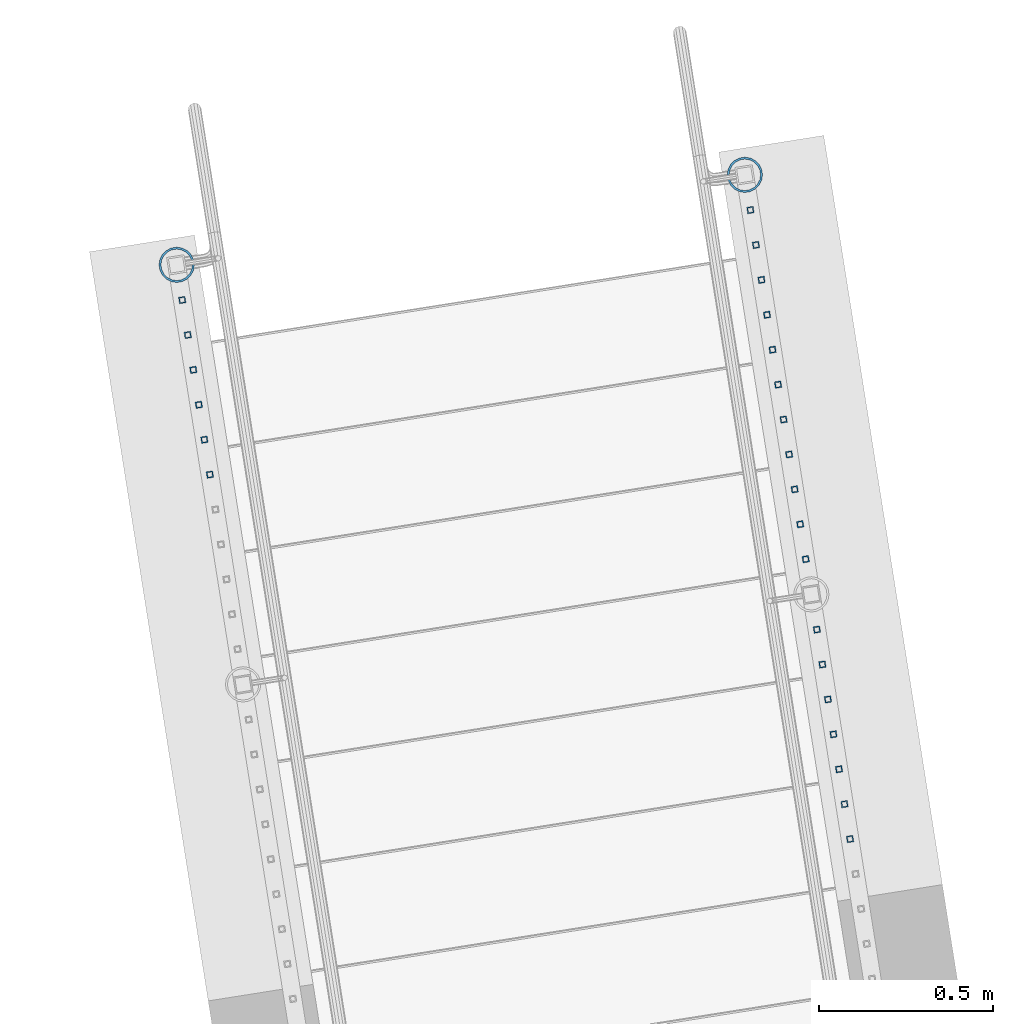
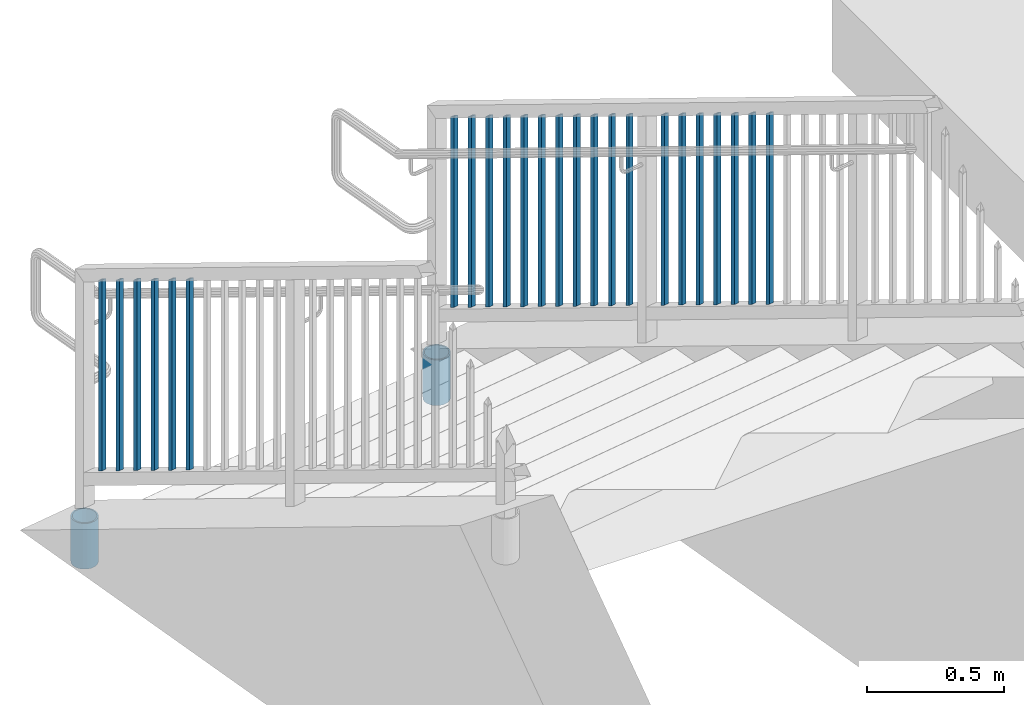
# One storey, part 229 of 975: 26 columns.
"""IFC2X3 building model written with IfcOpenShell, lengths in millimetres."""

from ifc_helpers import new_model, si_unit, frame, origin_with_axes, place, context, subcontext, project, spatial, faceted_brep, material, type_object, element, save


model = new_model("IFC2X3")

# Units and contexts
model_context = context("Model", 3, precision=1e-05, world=origin_with_axes())
body_context = subcontext(model_context, "Body", "Model", "MODEL_VIEW")
ifc_project = project(units=[si_unit("LENGTHUNIT", "METRE", prefix="MILLI"), si_unit("AREAUNIT", "SQUARE_METRE"), si_unit("VOLUMEUNIT", "CUBIC_METRE"), si_unit("MASSUNIT", "GRAM", prefix="KILO"), si_unit("TIMEUNIT", "SECOND"), si_unit("PLANEANGLEUNIT", "RADIAN"), si_unit("SOLIDANGLEUNIT", "STERADIAN"), si_unit("THERMODYNAMICTEMPERATUREUNIT", "DEGREE_CELSIUS"), si_unit("LUMINOUSINTENSITYUNIT", "LUMEN")], contexts=[model_context])

# Site, building, storey
site_placement = place(None, origin_with_axes())
site = spatial("IfcSite", under=ifc_project, at=site_placement, CompositionType="ELEMENT")
building_placement = place(site_placement, origin_with_axes())
building = spatial("IfcBuilding", under=site, at=building_placement, Name="Undefined", CompositionType="ELEMENT")
storey_placement = place(building_placement, origin_with_axes())
storey = spatial("IfcBuildingStorey", under=building, at=storey_placement, Name="Undefined", CompositionType="ELEMENT", Elevation=0.0)

# Columns
ifc_material_1 = material()
column_type_1 = type_object("IfcColumnType", Name="HSS3/4X3/4X.120_TUBES", PredefinedType="NOTDEFINED")
for number, where, z_axis, x_axis, name in (
    (1, (-1239.15545275308, 28982.8565701632, 258.604181437245), (-0.987688340611262, -0.156434464938429, 0.0), (0.0, 0.0, 1.0), "PICKET"),
    (2, (-1223.28352239707, 28882.6451459778, 314.618873890955), (-0.987688340611262, -0.156434464938429, 0.0), (0.0, 0.0, 1.0), "PICKET"),
    (3, (-1207.41159204106, 28782.4337217924, 370.633566344669), (-0.987688340611262, -0.156434464938429, 0.0), (0.0, 0.0, 1.0), "PICKET"),
    (4, (-1191.53966168505, 28682.2222976071, 426.648258798381), (-0.987688340611262, -0.156434464938429, 0.0), (0.0, 0.0, 1.0), "PICKET"),
    (5, (-1175.66773132905, 28582.0108734217, 482.662951252093), (-0.987688340611262, -0.156434464938429, 0.0), (0.0, 0.0, 1.0), "PICKET"),
    (6, (-1159.79580097304, 28481.7994492363, 538.677643705805), (-0.987688340611262, -0.156434464938429, 0.0), (0.0, 0.0, 1.0), "PICKET"),
    (7, (-1143.92387061703, 28381.588025051, 594.692336159517), (-0.987688340611262, -0.156434464938429, 0.0), (0.0, 0.0, 1.0), "PICKET"),
    (8, (-1128.05194026102, 28281.3766008656, 650.707028613229), (-0.987688340611262, -0.156434464938429, 0.0), (0.0, 0.0, 1.0), "PICKET"),
    (9, (-1112.18000990502, 28181.1651766802, 706.721721066939), (-0.987688340611262, -0.156434464938429, 0.0), (0.0, 0.0, 1.0), "PICKET"),
    (10, (-1096.30807954901, 28080.9537524949, 762.736413520653), (-0.987688340611262, -0.156434464938429, 0.0), (0.0, 0.0, 1.0), "PICKET"),
    (11, (-1080.436149193, 27980.7423283095, 818.751105974365), (-0.987688340611262, -0.156434464938429, 0.0), (0.0, 0.0, 1.0), "PICKET"),
):
    element("IfcColumn", number, at=place(storey_placement, frame(where, z_axis=z_axis, x_axis=x_axis)), inside=storey, type_object=column_type_1, material=ifc_material_1, Name=name, ObjectType="HSS3/4X3/4X.120_TUBES", context=body_context, shape_type="Brep", body=[
        faceted_brep([(-3.94394580574479, 6.34999999999127, -6.349999999999), (3.06751272214467, -6.34999999999491, -6.35000000000082), (852.242827714489, -6.34999999999491, -6.35000000000082), (845.231369186599, 6.34999999999127, -6.349999999999), (3.06751272214575, -6.34999999999127, 6.34999999999764), (852.24282771449, -6.34999999999127, 6.34999999999764), (-3.94394580574374, 6.34999999999854, 6.34999999999991), (845.2313691866, 6.34999999999854, 6.34999999999991), (-5.69681043771743, 9.5249999999869, -9.52499999999736), (-5.69681043771581, 9.52499999999782, 9.52499999999918), (843.478504554628, 9.52499999999782, 9.52499999999918), (843.478504554626, 9.5249999999869, -9.52499999999736), (4.82037735411836, -9.5249999999869, 9.52499999999645), (853.995692346462, -9.5249999999869, 9.52499999999645), (4.82037735411677, -9.52499999999782, -9.52500000000055), (853.995692346461, -9.52499999999782, -9.52500000000055)], [[[0, 1, 2, 3]], [[1, 4, 5, 2]], [[4, 6, 7, 5]], [[6, 0, 3, 7]], [[8, 9, 10, 11]], [[9, 12, 13, 10]], [[12, 14, 15, 13]], [[14, 8, 11, 15]], [[13, 15, 11, 10], [5, 7, 3, 2]], [[14, 12, 9, 8], [6, 4, 1, 0]]]),
    ])
for number, where, z_axis, x_axis, name in (
    (12, (-1048.43056880491, 27778.6670469398, 931.265927172524), (-0.987688340611262, -0.156434464938429, 0.0), (0.0, 0.0, 1.0), "PICKET"),
    (13, (-1032.5586384489, 27678.4556227545, 987.280619626236), (-0.987688340611262, -0.156434464938429, 0.0), (0.0, 0.0, 1.0), "PICKET"),
    (14, (-1016.68670809289, 27578.2441985691, 1043.29531207995), (-0.987688340611262, -0.156434464938429, 0.0), (0.0, 0.0, 1.0), "PICKET"),
    (15, (-1000.81477773689, 27478.0327743837, 1099.31000453366), (-0.987688340611262, -0.156434464938429, 0.0), (0.0, 0.0, 1.0), "PICKET"),
    (16, (-984.942847380876, 27377.8213501984, 1155.32469698738), (-0.987688340611262, -0.156434464938429, 0.0), (0.0, 0.0, 1.0), "PICKET"),
    (17, (-969.070917024868, 27277.609926013, 1211.33938944109), (-0.987688340611262, -0.156434464938429, 0.0), (0.0, 0.0, 1.0), "PICKET"),
    (18, (-953.198986668861, 27177.3985018276, 1267.3540818948), (-0.987688340611262, -0.156434464938429, 0.0), (0.0, 0.0, 1.0), "PICKET"),
):
    element("IfcColumn", number, at=place(storey_placement, frame(where, z_axis=z_axis, x_axis=x_axis)), inside=storey, type_object=column_type_1, material=ifc_material_1, Name=name, ObjectType="HSS3/4X3/4X.120_TUBES", context=body_context, shape_type="Brep", body=[
        faceted_brep([(-3.50571911954194, 6.34999999999491, -6.34999999999809), (3.50573940444565, -6.34999999999491, -6.34999999999991), (852.681084613786, -6.34999999999491, -6.34999999999991), (845.669626084644, 6.34999999999491, -6.34999999999809), (3.50571915819046, -6.34999999998763, 6.34999999999786), (852.681084601087, -6.34999999998763, 6.34999999999786), (-3.50573936579713, 6.34999999999854, 6.34999999999968), (845.669626071945, 6.34999999999854, 6.34999999999968), (-5.25857868897492, 9.5249999999869, -9.52499999999668), (-5.25860905835771, 9.52500000000146, 9.52499999999964), (843.916761436485, 9.52500000000146, 9.52499999999964), (843.916761455533, 9.5249999999869, -9.52499999999668), (5.25857872762344, -9.52499999998327, 9.52499999999645), (854.433949230198, -9.52499999998327, 9.52499999999645), (5.25860909700623, -9.52499999999418, -9.52499999999986), (854.433949249247, -9.52499999999418, -9.52499999999986)], [[[0, 1, 2, 3]], [[1, 4, 5, 2]], [[4, 6, 7, 5]], [[6, 0, 3, 7]], [[8, 9, 10, 11]], [[9, 12, 13, 10]], [[12, 14, 15, 13]], [[14, 8, 11, 15]], [[13, 15, 11, 10], [5, 7, 3, 2]], [[14, 12, 9, 8], [6, 4, 1, 0]]]),
    ])
for number, where, z_axis, x_axis, name in (
    (19, (-2870.02308635556, 28724.5525127473, 258.604181437245), (-0.987688340611262, -0.156434464938429, 0.0), (0.0, 0.0, 1.0), "PICKET"),
    (20, (-2854.15115599973, 28624.3410885622, 314.618873890955), (-0.987688340611262, -0.156434464938429, 0.0), (0.0, 0.0, 1.0), "PICKET"),
    (21, (-2838.27922564391, 28524.129664377, 370.633566344669), (-0.987688340611262, -0.156434464938429, 0.0), (0.0, 0.0, 1.0), "PICKET"),
    (22, (-2822.40729528808, 28423.9182401919, 426.648258798381), (-0.987688340611262, -0.156434464938429, 0.0), (0.0, 0.0, 1.0), "PICKET"),
    (23, (-2806.53536493226, 28323.7068160068, 482.662951252093), (-0.987688340611262, -0.156434464938429, 0.0), (0.0, 0.0, 1.0), "PICKET"),
    (24, (-2790.66343457643, 28223.4953918216, 538.677643705805), (-0.987688340611262, -0.156434464938429, 0.0), (0.0, 0.0, 1.0), "PICKET"),
):
    element("IfcColumn", number, at=place(storey_placement, frame(where, z_axis=z_axis, x_axis=x_axis)), inside=storey, type_object=column_type_1, material=ifc_material_1, Name=name, ObjectType="HSS3/4X3/4X.120_TUBES", context=body_context, shape_type="Brep", body=[
        faceted_brep([(-3.94394580574479, 6.34999999999127, -6.349999999999), (3.06751272214467, -6.34999999999491, -6.35000000000082), (852.242827714489, -6.34999999999491, -6.35000000000082), (845.231369186599, 6.34999999999127, -6.349999999999), (3.06751272214575, -6.34999999999127, 6.34999999999764), (852.24282771449, -6.34999999999127, 6.34999999999764), (-3.94394580574374, 6.34999999999854, 6.34999999999991), (845.2313691866, 6.34999999999854, 6.34999999999991), (-5.69681043771743, 9.5249999999869, -9.52499999999736), (-5.69681043771581, 9.52499999999782, 9.52499999999918), (843.478504554628, 9.52499999999782, 9.52499999999918), (843.478504554626, 9.5249999999869, -9.52499999999736), (4.82037735411836, -9.5249999999869, 9.52499999999645), (853.995692346462, -9.5249999999869, 9.52499999999645), (4.82037735411677, -9.52499999999782, -9.52500000000055), (853.995692346461, -9.52499999999782, -9.52500000000055)], [[[0, 1, 2, 3]], [[1, 4, 5, 2]], [[4, 6, 7, 5]], [[6, 0, 3, 7]], [[8, 9, 10, 11]], [[9, 12, 13, 10]], [[12, 14, 15, 13]], [[14, 8, 11, 15]], [[13, 15, 11, 10], [5, 7, 3, 2]], [[14, 12, 9, 8], [6, 4, 1, 0]]]),
    ])
ifc_material_2 = material(Name="STEEL/A53")
column_type_2 = type_object("IfcColumnType", Name="PIPE3-1/2STD", PredefinedType="NOTDEFINED")
column_1_placement = place(storey_placement, frame((-1255.16554664959, 29083.9365592306, -203.200008330914), z_axis=(0.587785252279345, 0.809016994384486, -8.09014238711826e-10), x_axis=(0.0, 0.0, 1.0)))
element("IfcColumn", 25, at=column_1_placement, inside=storey, type_object=column_type_2, material=ifc_material_2, ObjectType="PIPE3-1/2STD", context=body_context, shape_type="Brep", body=[
    faceted_brep([(0.0, -45.0595999999932, 1.45519152283669e-11), (0.0, -42.8542262016344, 13.924182159768), (203.199999999991, -42.8542262017145, 13.9241821598171), (203.19999999999, -45.0596000000478, 5.82076609134674e-11), (0.0, -36.45398215971, 26.4853683542424), (203.199999999993, -36.45398215981, 26.4853683542988), (0.0, -26.4853683541623, 36.45398215979), (203.199999999995, -26.4853683542788, 36.4539821598537), (0.0, -13.9241821596988, 42.8542262017108), (203.199999999998, -13.9241821598262, 42.8542262017836), (0.0, 3.63797880709171e-11, 45.0596000000514), (203.2, -9.27684595808387e-11, 45.0596000001387), (0.0, 13.9241821597716, 42.8542262017036), (203.200000000003, 13.9241821596443, 42.8542262017927), (0.0, 26.4853683542242, 36.4539821597718), (203.200000000006, 26.4853683541096, 36.4539821598701), (0.0, 36.4539821597537, 26.4853683542206), (203.200000000008, 36.4539821596554, 26.4853683543224), (0.0, 42.8542262016563, 13.9241821597425), (203.200000000009, 42.8542262015817, 13.9241821598443), (0.0, 45.0595999999932, -1.09139364212751e-11), (203.200000000009, 45.0595999999423, 8.9130480773747e-11), (0.0, 42.8542262016344, -13.9241821597643), (203.200000000008, 42.854226201609, -13.9241821596697), (0.0, 36.45398215971, -26.4853683542387), (203.200000000007, 36.4539821597045, -26.4853683541514), (0.0, 26.4853683541623, -36.4539821597864), (203.200000000004, 26.4853683541733, -36.4539821597064), (0.0, 13.9241821596988, -42.8542262017072), (203.200000000002, 13.9241821597225, -42.8542262016381), (0.0, -3.63797880709171e-11, -45.0596000000478), (203.199999999999, -9.09494701772928e-12, -45.0595999999914), (0.0, -13.9241821597716, -42.8542262016963), (203.199999999996, -13.9241821597479, -42.8542262016472), (0.0, -26.4853683542242, -36.4539821597682), (203.199999999993, -26.4853683542133, -36.4539821597227), (0.0, -36.4539821597537, -26.4853683542169), (203.199999999992, -36.4539821597609, -26.4853683541751), (0.0, -42.8542262016563, -13.9241821597352), (203.199999999991, -42.8542262016872, -13.924182159697), (0.0, -50.799999999992, 1.81898940354586e-11), (0.0, -48.3136710278013, -15.6980633142484), (203.199999999989, -48.313671027825, -15.6980633142139), (203.199999999989, -50.8000000000466, 5.63886715099216e-11), (0.0, -41.0980633142644, -29.8594908164741), (203.19999999999, -41.0980633142663, -29.8594908164414), (0.0, -29.859490816485, -41.0980633142826), (203.199999999993, -29.8594908164687, -41.0980633142426), (0.0, -15.6980633142848, -48.313671027845), (203.199999999995, -15.6980633142539, -48.313671027794), (0.0, -4.36557456851006e-11, -50.8000000000575), (203.199999999998, -7.27595761418343e-12, -50.7999999999993), (0.0, 15.6980633142011, -48.3136710278523), (203.200000000002, 15.6980633142375, -48.3136710277831), (0.0, 29.8594908164159, -41.0980633143045), (203.200000000005, 29.8594908164378, -41.0980633142226), (0.0, 41.0980633142135, -29.8594908165032), (203.200000000008, 41.0980633142171, -29.8594908164141), (0.0, 48.3136710277722, -15.6980633142775), (203.200000000009, 48.3136710277504, -15.6980633141811), (0.0, 50.799999999992, -1.45519152283669e-11), (203.20000000001, 50.7999999999411, 9.09494701772928e-11), (0.0, 48.313671027794, 15.6980633142521), (203.20000000001, 48.3136710277213, 15.6980633143594), (0.0, 41.0980633142644, 29.8594908164814), (203.200000000008, 41.0980633141626, 29.8594908165887), (0.0, 29.859490816485, 41.0980633142863), (203.200000000007, 29.8594908163632, 41.0980633143899), (0.0, 15.6980633142848, 48.3136710278486), (203.200000000004, 15.6980633141484, 48.3136710279414), (0.0, 4.00177668780088e-11, 50.8000000000611), (203.200000000001, -9.82254277914762e-11, 50.8000000001466), (0.0, -15.6980633142011, 48.3136710278559), (203.199999999997, -15.698063314343, 48.3136710279305), (0.0, -29.8594908164159, 41.0980633143081), (203.199999999994, -29.8594908165433, 41.0980633143681), (0.0, -41.0980633142171, 29.8594908165069), (203.199999999992, -41.0980633143226, 29.8594908165596), (0.0, -48.3136710277722, 15.6980633142812), (203.19999999999, -48.3136710278559, 15.6980633143285)], [[[0, 1, 2, 3]], [[1, 4, 5, 2]], [[4, 6, 7, 5]], [[6, 8, 9, 7]], [[8, 10, 11, 9]], [[10, 12, 13, 11]], [[12, 14, 15, 13]], [[14, 16, 17, 15]], [[16, 18, 19, 17]], [[18, 20, 21, 19]], [[20, 22, 23, 21]], [[22, 24, 25, 23]], [[24, 26, 27, 25]], [[26, 28, 29, 27]], [[28, 30, 31, 29]], [[30, 32, 33, 31]], [[32, 34, 35, 33]], [[34, 36, 37, 35]], [[36, 38, 39, 37]], [[38, 0, 3, 39]], [[40, 41, 42, 43]], [[41, 44, 45, 42]], [[44, 46, 47, 45]], [[46, 48, 49, 47]], [[48, 50, 51, 49]], [[50, 52, 53, 51]], [[52, 54, 55, 53]], [[54, 56, 57, 55]], [[56, 58, 59, 57]], [[58, 60, 61, 59]], [[60, 62, 63, 61]], [[62, 64, 65, 63]], [[64, 66, 67, 65]], [[66, 68, 69, 67]], [[68, 70, 71, 69]], [[70, 72, 73, 71]], [[72, 74, 75, 73]], [[74, 76, 77, 75]], [[76, 78, 79, 77]], [[78, 40, 43, 79]], [[45, 47, 49, 51, 53, 55, 57, 59, 61, 63, 65, 67, 69, 71, 73, 75, 77, 79, 43, 42], [5, 7, 9, 11, 13, 15, 17, 19, 21, 23, 25, 27, 29, 31, 33, 35, 37, 39, 3, 2]], [[78, 76, 74, 72, 70, 68, 66, 64, 62, 60, 58, 56, 54, 52, 50, 48, 46, 44, 41, 40], [38, 36, 34, 32, 30, 28, 26, 24, 22, 20, 18, 16, 14, 12, 10, 8, 6, 4, 1, 0]]]),
])
column_2_placement = place(storey_placement, frame((-2886.03243583243, 28825.6326198231, -203.200008534375), z_axis=(-0.587785252279345, -0.809016994384486, -8.09014181868407e-10), x_axis=(0.0, 0.0, 1.0)))
element("IfcColumn", 26, at=column_2_placement, inside=storey, type_object=column_type_2, material=ifc_material_2, ObjectType="PIPE3-1/2STD", context=body_context, shape_type="Brep", body=[
    faceted_brep([(0.0, -45.0595999999932, 1.45519152283669e-11), (0.0, -42.8542262016344, 13.924182159768), (203.199999999991, -42.8542262017145, 13.9241821598171), (203.19999999999, -45.0596000000478, 5.82076609134674e-11), (0.0, -36.45398215971, 26.4853683542424), (203.199999999993, -36.45398215981, 26.4853683542988), (0.0, -26.4853683541623, 36.45398215979), (203.199999999995, -26.4853683542788, 36.4539821598537), (0.0, -13.9241821596988, 42.8542262017108), (203.199999999998, -13.9241821598262, 42.8542262017836), (0.0, 3.63797880709171e-11, 45.0596000000514), (203.2, -9.27684595808387e-11, 45.0596000001387), (0.0, 13.9241821597716, 42.8542262017036), (203.200000000003, 13.9241821596443, 42.8542262017927), (0.0, 26.4853683542242, 36.4539821597718), (203.200000000006, 26.4853683541096, 36.4539821598701), (0.0, 36.4539821597537, 26.4853683542206), (203.200000000008, 36.4539821596554, 26.4853683543224), (0.0, 42.8542262016563, 13.9241821597425), (203.200000000009, 42.8542262015817, 13.9241821598443), (0.0, 45.0595999999932, -1.09139364212751e-11), (203.200000000009, 45.0595999999423, 8.9130480773747e-11), (0.0, 42.8542262016344, -13.9241821597643), (203.200000000008, 42.854226201609, -13.9241821596697), (0.0, 36.45398215971, -26.4853683542387), (203.200000000007, 36.4539821597045, -26.4853683541514), (0.0, 26.4853683541623, -36.4539821597864), (203.200000000004, 26.4853683541733, -36.4539821597064), (0.0, 13.9241821596988, -42.8542262017072), (203.200000000002, 13.9241821597225, -42.8542262016381), (0.0, -3.63797880709171e-11, -45.0596000000478), (203.199999999999, -9.09494701772928e-12, -45.0595999999914), (0.0, -13.9241821597716, -42.8542262016963), (203.199999999996, -13.9241821597479, -42.8542262016472), (0.0, -26.4853683542242, -36.4539821597682), (203.199999999993, -26.4853683542133, -36.4539821597227), (0.0, -36.4539821597537, -26.4853683542169), (203.199999999992, -36.4539821597609, -26.4853683541751), (0.0, -42.8542262016563, -13.9241821597352), (203.199999999991, -42.8542262016872, -13.924182159697), (0.0, -50.799999999992, 1.81898940354586e-11), (0.0, -48.3136710278013, -15.6980633142484), (203.199999999989, -48.313671027825, -15.6980633142139), (203.199999999989, -50.8000000000466, 5.63886715099216e-11), (0.0, -41.0980633142644, -29.8594908164741), (203.19999999999, -41.0980633142663, -29.8594908164414), (0.0, -29.859490816485, -41.0980633142826), (203.199999999993, -29.8594908164687, -41.0980633142426), (0.0, -15.6980633142848, -48.313671027845), (203.199999999995, -15.6980633142539, -48.313671027794), (0.0, -4.36557456851006e-11, -50.8000000000575), (203.199999999998, -7.27595761418343e-12, -50.7999999999993), (0.0, 15.6980633142011, -48.3136710278523), (203.200000000002, 15.6980633142375, -48.3136710277831), (0.0, 29.8594908164159, -41.0980633143045), (203.200000000005, 29.8594908164378, -41.0980633142226), (0.0, 41.0980633142135, -29.8594908165032), (203.200000000008, 41.0980633142171, -29.8594908164141), (0.0, 48.3136710277722, -15.6980633142775), (203.200000000009, 48.3136710277504, -15.6980633141811), (0.0, 50.799999999992, -1.45519152283669e-11), (203.20000000001, 50.7999999999411, 9.09494701772928e-11), (0.0, 48.313671027794, 15.6980633142521), (203.20000000001, 48.3136710277213, 15.6980633143594), (0.0, 41.0980633142644, 29.8594908164814), (203.200000000008, 41.0980633141626, 29.8594908165887), (0.0, 29.859490816485, 41.0980633142863), (203.200000000007, 29.8594908163632, 41.0980633143899), (0.0, 15.6980633142848, 48.3136710278486), (203.200000000004, 15.6980633141484, 48.3136710279414), (0.0, 4.00177668780088e-11, 50.8000000000611), (203.200000000001, -9.82254277914762e-11, 50.8000000001466), (0.0, -15.6980633142011, 48.3136710278559), (203.199999999997, -15.698063314343, 48.3136710279305), (0.0, -29.8594908164159, 41.0980633143081), (203.199999999994, -29.8594908165433, 41.0980633143681), (0.0, -41.0980633142171, 29.8594908165069), (203.199999999992, -41.0980633143226, 29.8594908165596), (0.0, -48.3136710277722, 15.6980633142812), (203.19999999999, -48.3136710278559, 15.6980633143285)], [[[0, 1, 2, 3]], [[1, 4, 5, 2]], [[4, 6, 7, 5]], [[6, 8, 9, 7]], [[8, 10, 11, 9]], [[10, 12, 13, 11]], [[12, 14, 15, 13]], [[14, 16, 17, 15]], [[16, 18, 19, 17]], [[18, 20, 21, 19]], [[20, 22, 23, 21]], [[22, 24, 25, 23]], [[24, 26, 27, 25]], [[26, 28, 29, 27]], [[28, 30, 31, 29]], [[30, 32, 33, 31]], [[32, 34, 35, 33]], [[34, 36, 37, 35]], [[36, 38, 39, 37]], [[38, 0, 3, 39]], [[40, 41, 42, 43]], [[41, 44, 45, 42]], [[44, 46, 47, 45]], [[46, 48, 49, 47]], [[48, 50, 51, 49]], [[50, 52, 53, 51]], [[52, 54, 55, 53]], [[54, 56, 57, 55]], [[56, 58, 59, 57]], [[58, 60, 61, 59]], [[60, 62, 63, 61]], [[62, 64, 65, 63]], [[64, 66, 67, 65]], [[66, 68, 69, 67]], [[68, 70, 71, 69]], [[70, 72, 73, 71]], [[72, 74, 75, 73]], [[74, 76, 77, 75]], [[76, 78, 79, 77]], [[78, 40, 43, 79]], [[45, 47, 49, 51, 53, 55, 57, 59, 61, 63, 65, 67, 69, 71, 73, 75, 77, 79, 43, 42], [5, 7, 9, 11, 13, 15, 17, 19, 21, 23, 25, 27, 29, 31, 33, 35, 37, 39, 3, 2]], [[78, 76, 74, 72, 70, 68, 66, 64, 62, 60, 58, 56, 54, 52, 50, 48, 46, 44, 41, 40], [38, 36, 34, 32, 30, 28, 26, 24, 22, 20, 18, 16, 14, 12, 10, 8, 6, 4, 1, 0]]]),
])

save(model, "model.ifc")
